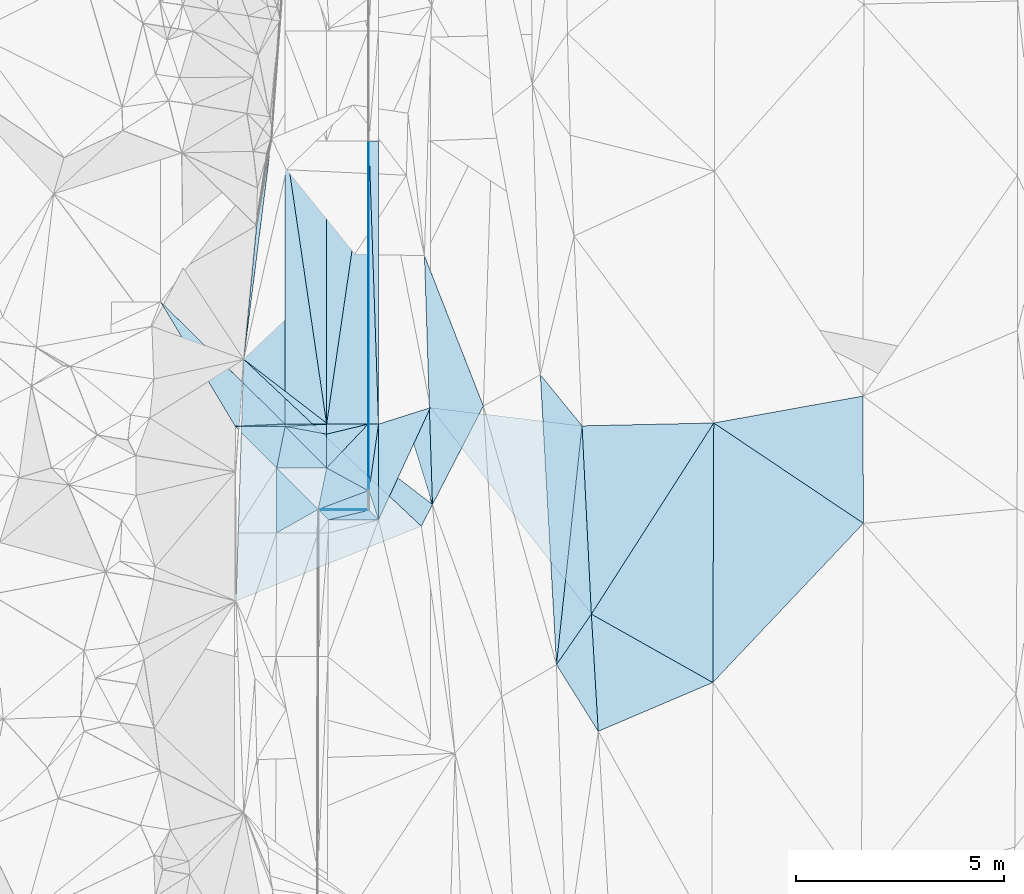
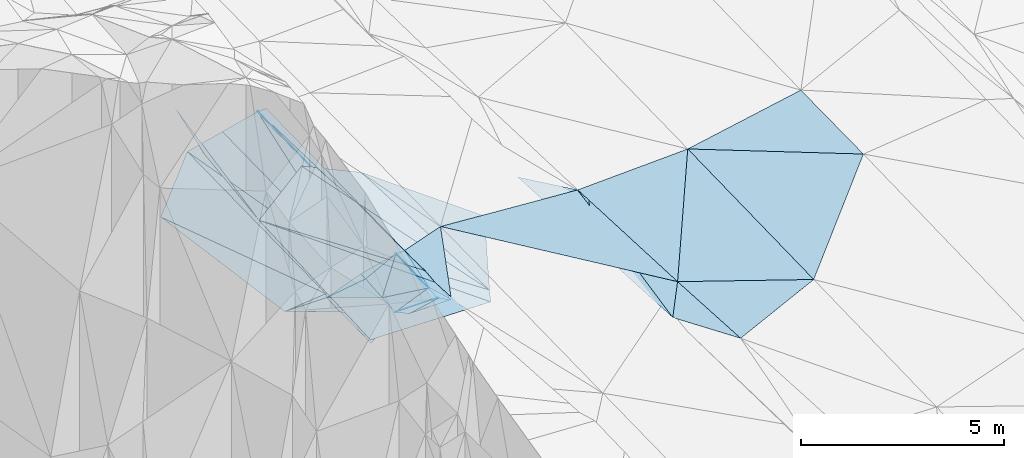
# One storey, part 129 of 275: 46 plates.
"""IFC2X3 building model written with IfcOpenShell, lengths in millimetres."""

import ifcopenshell
import ifcopenshell.guid

model = None  # the IFC model being written
_history = None  # IfcOwnerHistory: only IFC2X3 demands one
_inside = {}  # id of a spatial element -> (the spatial element, [elements in it])
_under = {}  # id of a project, library or spatial element -> (it, [spatial elements below it])
_declared = {}  # id of a project -> (the project, [libraries it declares])
_typed = {}  # id of a type object -> (the type object, [elements of that type])
_made_of = {}  # id of a material, layer set ... -> (it, [elements and type objects made of it])


def new_model(schema):
    """Start an empty IFC model of exactly this schema.

    Asked for "IFC4X3", IfcOpenShell would pick the latest addendum, in which some entities
    have other attributes; the version numbers below select the first issue.
    IFC2X3 requires an IfcOwnerHistory on every rooted entity: one is made here for all.
    """
    global model, _history
    if schema == "IFC4X3":
        model = ifcopenshell.file(schema_version=(4, 3, 0, 0))
    else:
        model = ifcopenshell.file(schema=schema)
    _inside.clear()
    _under.clear()
    _declared.clear()
    _typed.clear()
    _made_of.clear()
    _history = None
    if model.schema == "IFC2X3":
        org = make("IfcOrganization", Name="unknown")
        user = make(
            "IfcPersonAndOrganization",
            ThePerson=make("IfcPerson", FamilyName="unknown"),
            TheOrganization=org,
        )
        app = make(
            "IfcApplication",
            ApplicationDeveloper=org,
            Version="unknown",
            ApplicationFullName="unknown",
            ApplicationIdentifier="unknown",
        )
        _history = make(
            "IfcOwnerHistory",
            OwningUser=user,
            OwningApplication=app,
            ChangeAction="ADDED",
            CreationDate=0,
        )
    return model


def make(cls, **values):
    """One entity of the class cls with the attributes given. An attribute that is None is left unset."""
    return model.create_entity(
        cls, **{name: value for name, value in values.items() if value is not None}
    )


def rooted(cls, **values):
    """An entity with a GlobalId (a new one), such as an element, a storey or a relation."""
    return make(cls, GlobalId=ifcopenshell.guid.new(), OwnerHistory=_history, **values)


def si_unit(unit_type, name, prefix=None):
    """IfcSIUnit, for example si_unit("LENGTHUNIT", "METRE", prefix="MILLI")."""
    return make("IfcSIUnit", UnitType=unit_type, Prefix=prefix, Name=name)


def assignment(units):
    """IfcUnitAssignment: the units of a project."""
    return None if units is None else make("IfcUnitAssignment", Units=units)


def point(xyz):
    """IfcCartesianPoint."""
    return None if xyz is None else make("IfcCartesianPoint", Coordinates=xyz)


def direction(xyz):
    """IfcDirection."""
    return None if xyz is None else make("IfcDirection", DirectionRatios=xyz)


def frame(location, z_axis=None, x_axis=None):
    """IfcAxis2Placement3D, a coordinate frame: its origin and axes. An axis left out is left unset."""
    return make(
        "IfcAxis2Placement3D",
        Location=point(location),
        Axis=direction(z_axis),
        RefDirection=direction(x_axis),
    )


def origin_with_axes():
    """The frame at (0, 0, 0) with the z axis (0, 0, 1) and the x axis (1, 0, 0) written out."""
    return frame((0.0, 0.0, 0.0), z_axis=(0.0, 0.0, 1.0), x_axis=(1.0, 0.0, 0.0))


def place(relative_to, where):
    """IfcLocalPlacement: puts the frame where relative to a parent placement (None: the world)."""
    return make(
        "IfcLocalPlacement", PlacementRelTo=relative_to, RelativePlacement=where
    )


def context(
    kind, dimensions, precision=None, world=None, true_north=None, identifier=None
):
    """IfcGeometricRepresentationContext, for example the 3D "Model" context."""
    return make(
        "IfcGeometricRepresentationContext",
        ContextIdentifier=identifier,
        ContextType=kind,
        CoordinateSpaceDimension=dimensions,
        Precision=precision,
        WorldCoordinateSystem=world,
        TrueNorth=true_north,
    )


def subcontext(parent, identifier, kind, view, scale=None):
    """IfcGeometricRepresentationSubContext, for example "Body" below "Model"."""
    return make(
        "IfcGeometricRepresentationSubContext",
        ContextIdentifier=identifier,
        ContextType=kind,
        ParentContext=parent,
        TargetScale=scale,
        TargetView=view,
    )


def project(units=None, contexts=None):
    """IfcProject with its units and contexts."""
    return rooted(
        "IfcProject",
        Name="project",
        RepresentationContexts=contexts,
        UnitsInContext=assignment(units),
    )


def spatial(cls, under=None, at=None, **own):
    """A site, building, storey or space (cls), placed at a placement, below another one or the project."""
    s = rooted(cls, ObjectPlacement=at, **own)
    if under is not None:
        _under.setdefault(under.id(), (under, []))[1].append(s)
    return s


def polyline(points):
    """IfcPolyline through the points."""
    return make("IfcPolyline", Points=[point(p) for p in points])


def outline(outer, holes=None, kind="AREA"):
    """IfcArbitraryClosedProfileDef: a profile drawn as a closed curve; with holes, ...WithVoids."""
    if holes is None:
        return make("IfcArbitraryClosedProfileDef", ProfileType=kind, OuterCurve=outer)
    return make(
        "IfcArbitraryProfileDefWithVoids",
        ProfileType=kind,
        OuterCurve=outer,
        InnerCurves=holes,
    )


def extrude(swept, where, along, depth):
    """IfcExtrudedAreaSolid: the profile swept, set in the frame where, extruded along a direction by depth."""
    return make(
        "IfcExtrudedAreaSolid",
        SweptArea=swept,
        Position=where,
        ExtrudedDirection=direction(along),
        Depth=depth,
    )


def shape(context_of_items, identifier, shape_type, items):
    """IfcShapeRepresentation: the items that make up one representation, for example the "Body"."""
    return make(
        "IfcShapeRepresentation",
        ContextOfItems=context_of_items,
        RepresentationIdentifier=identifier,
        RepresentationType=shape_type,
        Items=items,
    )


def material(Name=None, Category=None):
    """IfcMaterial."""
    return make("IfcMaterial", Name=Name, Category=Category)


def made_of(thing, what):
    """Note that an element or type object is made of a material, layer set ...; save() writes the relation."""
    if what is not None:
        _made_of.setdefault(what.id(), (what, []))[1].append(thing)
    return thing


def type_object(cls, material=None, **own):
    """A type object (cls), such as IfcWallType, which elements share."""
    return made_of(rooted(cls, **own), material)


def element(
    cls,
    number,
    at=None,
    inside=None,
    cuts=None,
    type_object=None,
    material=None,
    context=None,
    identifier="Body",
    shape_type=None,
    held_by="IfcProductDefinitionShape",
    body=None,
    shapes=None,
    **own,
):
    """One element of the class cls, such as IfcWall. Its Tag is "e" and its number.

    at: its placement. inside: the storey or other place that contains it. cuts: it is an
    opening in that element (IfcRelVoidsElement). A single representation is given by context,
    identifier, shape_type and body (its items); several are given by shapes. held_by: the class
    of the entity that holds the representations. save() writes the other relations.
    """
    e = rooted(cls, Tag="e%d" % number, ObjectPlacement=at, **own)
    if body is not None:
        shapes = [shape(context, identifier, shape_type, body)]
    if shapes is not None:
        e.Representation = make(held_by, Representations=shapes)
    if inside is not None:
        _inside.setdefault(inside.id(), (inside, []))[1].append(e)
    if cuts is not None:
        rooted(
            "IfcRelVoidsElement", RelatingBuildingElement=cuts, RelatedOpeningElement=e
        )
    if type_object is not None:
        _typed.setdefault(type_object.id(), (type_object, []))[1].append(e)
    return made_of(e, material)


def aggregate(whole, parts):
    """IfcRelAggregates: a whole, such as a stair, and the parts it consists of."""
    return rooted("IfcRelAggregates", RelatingObject=whole, RelatedObjects=parts)


def save(model, path):
    """Write the relations noted so far, then the file.

    IfcRelAggregates (storeys below a building ...), IfcRelContainedInSpatialStructure (elements
    in a storey), IfcRelDefinesByType, IfcRelAssociatesMaterial and IfcRelDeclares: one each for
    every whole, place, type object, material and project.
    """
    for whole, parts in _under.values():
        aggregate(whole, parts)
    for where, things in _inside.values():
        rooted(
            "IfcRelContainedInSpatialStructure",
            RelatedElements=things,
            RelatingStructure=where,
        )
    for kind, things in _typed.values():
        rooted("IfcRelDefinesByType", RelatedObjects=things, RelatingType=kind)
    for what, things in _made_of.values():
        rooted("IfcRelAssociatesMaterial", RelatedObjects=things, RelatingMaterial=what)
    for by, libraries in _declared.values():
        rooted("IfcRelDeclares", RelatingContext=by, RelatedDefinitions=libraries)
    model.write(path)


model = new_model("IFC2X3")

# Units and contexts
model_context = context("Model", 3, precision=1e-05, world=origin_with_axes())
body_context = subcontext(model_context, "Body", "Model", "MODEL_VIEW")
ifc_project = project(units=[si_unit("LENGTHUNIT", "METRE", prefix="MILLI"), si_unit("AREAUNIT", "SQUARE_METRE"), si_unit("VOLUMEUNIT", "CUBIC_METRE"), si_unit("MASSUNIT", "GRAM", prefix="KILO"), si_unit("TIMEUNIT", "SECOND"), si_unit("PLANEANGLEUNIT", "RADIAN"), si_unit("SOLIDANGLEUNIT", "STERADIAN"), si_unit("THERMODYNAMICTEMPERATUREUNIT", "DEGREE_CELSIUS"), si_unit("LUMINOUSINTENSITYUNIT", "LUMEN")], contexts=[model_context])

# Site, building, storey
site_placement = place(None, origin_with_axes())
site = spatial("IfcSite", under=ifc_project, at=site_placement, CompositionType="ELEMENT")
building_placement = place(site_placement, origin_with_axes())
building = spatial("IfcBuilding", under=site, at=building_placement, Name="Undefined", CompositionType="ELEMENT")
storey_placement = place(building_placement, origin_with_axes())
storey = spatial("IfcBuildingStorey", under=building, at=storey_placement, Name="Undefined", CompositionType="ELEMENT", Elevation=0.0)

# Plates
ifc_material = material()
plate_type_1 = type_object("IfcPlateType", PredefinedType="NOTDEFINED")
plate_1_placement = place(storey_placement, frame((-97653.2887864326, 105542.547100764, 42493.7394026533), z_axis=(0.312892359735488, 0.0336666386095785, -0.949191723870309), x_axis=(0.947866294842102, 0.0524820300685119, 0.314316915902079)))
element("IfcPlate", 1, at=plate_1_placement, inside=storey, type_object=plate_type_1, material=ifc_material, Name="00_PR", context=body_context, shape_type="SweptSolid", body=[
    extrude(outline(polyline([(0.0, 0.0), (1054.98303222656, 7.8580342233181e-10), (1039.69421386719, 241.215286254883), (0.0, 0.0)])), frame((-8.85201319254618e-08, 2.18876761149539e-07, -0.5000001331573), z_axis=(0.0, 0.0, 1.0), x_axis=(1.0, 0.0, 0.0)), (0.0, 0.0, 1.0), 1.0),
])
plate_type_2 = type_object("IfcPlateType", PredefinedType="NOTDEFINED")
plate_2_placement = place(storey_placement, frame((-95655.6246239259, 112422.738065475, 43216.1967279193), z_axis=(0.0499223744900721, 0.0206295436102709, -0.998540023462107), x_axis=(0.998752208044659, 0.000305680057574922, 0.0499392980088953)))
element("IfcPlate", 2, at=plate_2_placement, inside=storey, type_object=plate_type_2, material=ifc_material, Name="00_PR", context=body_context, shape_type="SweptSolid", body=[
    extrude(outline(polyline([(0.0, 0.0), (20.0243110656738, 1.45519152283669e-11), (-6.93724489212036, 6825.95947265625), (0.0, 0.0)])), frame((-8.85201319254618e-08, 2.18876761149539e-07, -0.5000001331573), z_axis=(0.0, 0.0, 1.0), x_axis=(1.0, 0.0, 0.0)), (0.0, 0.0, 1.0), 1.0),
])
plate_3_placement = place(storey_placement, frame((-95635.6252984131, 112422.744185168, 43217.1967278183), z_axis=(0.0499223744900721, 0.0206295436102709, -0.998540023462107), x_axis=(0.000320483071139451, -0.99978693596693, -0.0206392819753496)))
element("IfcPlate", 3, at=plate_3_placement, inside=storey, type_object=plate_type_2, material=ifc_material, Name="00_PR", context=body_context, shape_type="SweptSolid", body=[
    extrude(outline(polyline([(0.0, 0.0), (6825.96337890625, 3.34839569404721e-08), (6825.9833984375, 20.024299621582), (0.0, 0.0)])), frame((-8.85201319254618e-08, 2.18876761149539e-07, -0.5000001331573), z_axis=(0.0, 0.0, 1.0), x_axis=(1.0, 0.0, 0.0)), (0.0, 0.0, 1.0), 1.0),
])
plate_4_placement = place(storey_placement, frame((-95653.4374348788, 105598.236543643, 43075.3139315699), z_axis=(0.0498975874379128, 0.0352089020594793, -0.998133540155646), x_axis=(0.998752208044659, 0.000305680057574922, 0.0499392980088953)))
element("IfcPlate", 4, at=plate_4_placement, inside=storey, type_object=plate_type_2, material=ifc_material, Name="00_PR", context=body_context, shape_type="SweptSolid", body=[
    extrude(outline(polyline([(0.0, 0.0), (20.0243110656738, 1.45519152283669e-11), (-2.80114841461182, 1604.79565429688), (0.0, 0.0)])), frame((-8.85201319254618e-08, 2.18876761149539e-07, -0.5000001331573), z_axis=(0.0, 0.0, 1.0), x_axis=(1.0, 0.0, 0.0)), (0.0, 0.0, 1.0), 1.0),
])
plate_5_placement = place(storey_placement, frame((-95633.4381117361, 105598.242665022, 43076.3139315634), z_axis=(0.049894601856358, 0.0352089441059493, -0.99813368791988), x_axis=(0.000320679087443506, -0.999378938278334, -0.0352368399632018)))
element("IfcPlate", 5, at=plate_5_placement, inside=storey, type_object=plate_type_2, material=ifc_material, Name="00_PR", context=body_context, shape_type="SweptSolid", body=[
    extrude(outline(polyline([(0.0, 0.0), (1604.79772949219, 7.02857505530119e-09), (1604.8330078125, 20.0251922607422), (0.0, 0.0)])), frame((-8.85201319254618e-08, 2.18876761149539e-07, -0.5000001331573), z_axis=(0.0, 0.0, 1.0), x_axis=(1.0, 0.0, 0.0)), (0.0, 0.0, 1.0), 1.0),
])
plate_6_placement = place(storey_placement, frame((-95632.7954361598, 103522.392015706, 42994.7145218657), z_axis=(0.00441215188148387, -0.0455324207746714, -0.998953117805922), x_axis=(-0.999990232290027, 5.52519184112805e-05, -0.00441953298023441)))
element("IfcPlate", 6, at=plate_6_placement, inside=storey, type_object=plate_type_2, material=ifc_material, Name="00_PR", context=body_context, shape_type="SweptSolid", body=[
    extrude(outline(polyline([(0.0, 0.0), (1207.6669921875, -1.92085281014442e-09), (20.0108661651611, 20.020471572876), (0.0, 0.0)])), frame((-8.85201319254618e-08, 2.18876761149539e-07, -0.5000001331573), z_axis=(0.0, 0.0, 1.0), x_axis=(1.0, 0.0, 0.0)), (0.0, 0.0, 1.0), 1.0),
])
plate_7_placement = place(storey_placement, frame((-95652.8009657944, 103542.392823774, 42993.7145216319), z_axis=(0.00441242987111564, -0.0455490928932025, -0.99895235652119), x_axis=(-0.999852510334156, -0.0167817230790886, -0.00365121198830028)))
element("IfcPlate", 7, at=plate_7_placement, inside=storey, type_object=plate_type_2, material=ifc_material, Name="00_PR", context=body_context, shape_type="SweptSolid", body=[
    extrude(outline(polyline([(0.0, 0.0), (1187.82482910156, -2.95403879135847e-09), (1207.42211914063, 20.3533382415771), (0.0, 0.0)])), frame((-8.85201319254618e-08, 2.18876761149539e-07, -0.5000001331573), z_axis=(0.0, 0.0, 1.0), x_axis=(1.0, 0.0, 0.0)), (0.0, 0.0, 1.0), 1.0),
])
plate_type_3 = type_object("IfcPlateType", PredefinedType="NOTDEFINED")
plate_8_placement = place(storey_placement, frame((-96653.3411720604, 105597.90797045, 42825.3280256418), z_axis=(0.242480539180767, 0.0201010242110284, -0.96994800734074), x_axis=(-0.970142403271045, -0.000311047105442569, -0.242535813077531)))
element("IfcPlate", 8, at=plate_8_placement, inside=storey, type_object=plate_type_3, material=ifc_material, Name="00_PR", context=body_context, shape_type="SweptSolid", body=[
    extrude(outline(polyline([(0.0, 0.0), (1030.77648925781, -5.90807758271694e-09), (996.604248046875, 6825.87841796875), (0.0, 0.0)])), frame((-8.85201319254618e-08, 2.18876761149539e-07, -0.5000001331573), z_axis=(0.0, 0.0, 1.0), x_axis=(1.0, 0.0, 0.0)), (0.0, 0.0, 1.0), 1.0),
])
plate_9_placement = place(storey_placement, frame((-97655.5288255688, 112422.096666307, 42716.2110240052), z_axis=(0.242480539180767, 0.0201010242110284, -0.96994800734074), x_axis=(0.970142455388523, 0.000311440077304942, 0.242535604103411)))
element("IfcPlate", 9, at=plate_9_placement, inside=storey, type_object=plate_type_3, material=ifc_material, Name="00_PR", context=body_context, shape_type="SweptSolid", body=[
    extrude(outline(polyline([(0.0, 0.0), (1030.77648925781, -5.90807758271694e-09), (996.604187011719, 6825.87841796875), (0.0, 0.0)])), frame((-8.85201319254618e-08, 2.18876761149539e-07, -0.5000001331573), z_axis=(0.0, 0.0, 1.0), x_axis=(1.0, 0.0, 0.0)), (0.0, 0.0, 1.0), 1.0),
])
plate_type_4 = type_object("IfcPlateType", PredefinedType="NOTDEFINED")
plate_10_placement = place(storey_placement, frame((-95635.6252984131, 112422.744185168, 43217.1967278183), z_axis=(0.0499202695724449, 0.0206295454221238, -0.998540128658579), x_axis=(0.998752289393171, 0.000323471066674541, 0.0499375589949035)))
element("IfcPlate", 10, at=plate_10_placement, inside=storey, type_object=plate_type_4, material=ifc_material, Name="00_PR", context=body_context, shape_type="SweptSolid", body=[
    extrude(outline(polyline([(0.0, 0.0), (230.287582397461, -1.16415321826935e-10), (223.229583740234, 6825.96044921875), (0.0, 0.0)])), frame((-8.85201319254618e-08, 2.18876761149539e-07, -0.5000001331573), z_axis=(0.0, 0.0, 1.0), x_axis=(1.0, 0.0, 0.0)), (0.0, 0.0, 1.0), 1.0),
])
plate_11_placement = place(storey_placement, frame((-95403.4374353399, 105598.308952876, 43087.8137283719), z_axis=(0.0499202695724449, 0.0206295454221238, -0.998540128658579), x_axis=(-0.998752295023271, -0.000319498066804367, -0.0499374719698073)))
element("IfcPlate", 11, at=plate_11_placement, inside=storey, type_object=plate_type_4, material=ifc_material, Name="00_PR", context=body_context, shape_type="SweptSolid", body=[
    extrude(outline(polyline([(0.0, 0.0), (230.287994384766, 9.60426405072212e-10), (223.256713867188, 6825.95947265625), (0.0, 0.0)])), frame((-8.85201319254618e-08, 2.18876761149539e-07, -0.5000001331573), z_axis=(0.0, 0.0, 1.0), x_axis=(1.0, 0.0, 0.0)), (0.0, 0.0, 1.0), 1.0),
])
plate_12_placement = place(storey_placement, frame((-95632.9239308959, 103994.441690394, 43019.765911747), z_axis=(0.0490039818531292, 0.0353381512755968, -0.998173243894546), x_axis=(0.141515003891181, 0.989046333769192, 0.0419625229389179)))
element("IfcPlate", 12, at=plate_12_placement, inside=storey, type_object=plate_type_4, material=ifc_material, Name="00_PR", context=body_context, shape_type="SweptSolid", body=[
    extrude(outline(polyline([(0.0, 0.0), (1621.63745117188, 1.05210347101092e-08), (-662.321350097656, 327.6484375), (0.0, 0.0)])), frame((-8.85201319254618e-08, 2.18876761149539e-07, -0.5000001331573), z_axis=(0.0, 0.0, 1.0), x_axis=(1.0, 0.0, 0.0)), (0.0, 0.0, 1.0), 1.0),
])
plate_13_placement = place(storey_placement, frame((-95632.7954361598, 103522.392015706, 42994.7145218657), z_axis=(0.00440892437051324, -0.0455346349813954, -0.998953031129595), x_axis=(0.706758614821674, -0.706572215713133, 0.0353265389980809)))
element("IfcPlate", 13, at=plate_13_placement, inside=storey, type_object=plate_type_4, material=ifc_material, Name="00_PR", context=body_context, shape_type="SweptSolid", body=[
    extrude(outline(polyline([(0.0, 0.0), (325.534301757813, 3.62888386007398e-10), (-528.830078125, 854.747009277344), (0.0, 0.0)])), frame((-8.85201319254618e-08, 2.18876761149539e-07, -0.5000001331573), z_axis=(0.0, 0.0, 1.0), x_axis=(1.0, 0.0, 0.0)), (0.0, 0.0, 1.0), 1.0),
])
plate_14_placement = place(storey_placement, frame((-96611.23374733, 103292.448182768, 43000.8775216555), z_axis=(0.00441214773488253, -0.0455483362832968, -0.998952392266113), x_axis=(-0.705440935818661, 0.70788449171914, -0.0353925480126398)))
element("IfcPlate", 14, at=plate_14_placement, inside=storey, type_object=plate_type_4, material=ifc_material, Name="00_PR", context=body_context, shape_type="SweptSolid", body=[
    extrude(outline(polyline([(0.0, 0.0), (324.927154541016, -3.71983333025128e-10), (-527.238647460938, 855.729553222656), (0.0, 0.0)])), frame((-8.85201319254618e-08, 2.18876761149539e-07, -0.5000001331573), z_axis=(0.0, 0.0, 1.0), x_axis=(1.0, 0.0, 0.0)), (0.0, 0.0, 1.0), 1.0),
])
plate_type_5 = type_object("IfcPlateType", PredefinedType="NOTDEFINED")
plate_15_placement = place(storey_placement, frame((-100654.386689466, 108542.953911166, 44147.5779243055), z_axis=(0.0396122744760704, 0.501672436813122, -0.864150238010044), x_axis=(0.668508670926033, -0.656074341843081, -0.350232229915918)))
element("IfcPlate", 15, at=plate_15_placement, inside=storey, type_object=plate_type_5, material=ifc_material, Name="00_PR", context=body_context, shape_type="SweptSolid", body=[
    extrude(outline(polyline([(0.0, 0.0), (4489.0126953125, 3.69327608495951e-08), (3753.52294921875, 953.418518066406), (0.0, 0.0)])), frame((-8.85201319254618e-08, 2.18876761149539e-07, -0.5000001331573), z_axis=(0.0, 0.0, 1.0), x_axis=(1.0, 0.0, 0.0)), (0.0, 0.0, 1.0), 1.0),
])
plate_type_6 = type_object("IfcPlateType", PredefinedType="NOTDEFINED")
plate_16_placement = place(storey_placement, frame((-97655.8749804858, 112422.095759161, 42716.2495411384), z_axis=(-0.449850908170147, 0.018288880229569, -0.892916388738857), x_axis=(0.000320483071139451, -0.99978693596693, -0.0206392819753496)))
element("IfcPlate", 16, at=plate_16_placement, inside=storey, type_object=plate_type_6, material=ifc_material, Name="00_PR", context=body_context, shape_type="SweptSolid", body=[
    extrude(outline(polyline([(0.0, 0.0), (6825.9638671875, 9.77888703346252e-09), (3848.0546875, 3359.06127929688), (0.0, 0.0)])), frame((-8.85201319254618e-08, 2.18876761149539e-07, -0.5000001331573), z_axis=(0.0, 0.0, 1.0), x_axis=(1.0, 0.0, 0.0)), (0.0, 0.0, 1.0), 1.0),
])
plate_type_7 = type_object("IfcPlateType", PredefinedType="NOTDEFINED")
plate_17_placement = place(storey_placement, frame((-97653.443979192, 105542.944770362, 42493.9343780925), z_axis=(0.00250687886112322, 0.829000339173588, -0.559242481584198), x_axis=(-0.99999010568678, 2.3083920952297e-05, -0.00444837000210097)))
element("IfcPlate", 17, at=plate_17_placement, inside=storey, type_object=plate_type_7, material=ifc_material, Name="00_PR", context=body_context, shape_type="SweptSolid", body=[
    extrude(outline(polyline([(0.0, 0.0), (1199.76538085938, 8.23638401925564e-09), (-0.344492018222809, 98.4297180175781), (0.0, 0.0)])), frame((-8.85201319254618e-08, 2.18876761149539e-07, -0.5000001331573), z_axis=(0.0, 0.0, 1.0), x_axis=(1.0, 0.0, 0.0)), (0.0, 0.0, 1.0), 1.0),
])
plate_type_8 = type_object("IfcPlateType", PredefinedType="NOTDEFINED")
plate_18_placement = place(storey_placement, frame((-97856.871913565, 104542.381525309, 42738.3914295413), z_axis=(0.00431452632143643, -0.238472600232204, -0.971139641761736), x_axis=(-0.694969408010111, 0.697572935905946, -0.174383259006232)))
element("IfcPlate", 18, at=plate_18_placement, inside=storey, type_object=plate_type_8, material=ifc_material, Name="00_PR", context=body_context, shape_type="SweptSolid", body=[
    extrude(outline(polyline([(0.0, 0.0), (1433.62390136719, -5.64796209800988e-10), (598.8818359375, 861.767272949219), (0.0, 0.0)])), frame((-8.85201319254618e-08, 2.18876761149539e-07, -0.5000001331573), z_axis=(0.0, 0.0, 1.0), x_axis=(1.0, 0.0, 0.0)), (0.0, 0.0, 1.0), 1.0),
])
plate_type_9 = type_object("IfcPlateType", PredefinedType="NOTDEFINED")
plate_19_placement = place(storey_placement, frame((-96653.3411720604, 105597.90797045, 42825.3280256418), z_axis=(0.242480539180767, 0.0201010242110284, -0.96994800734074), x_axis=(-0.000320483060127504, 0.999786935966934, 0.0206392819753454)))
element("IfcPlate", 19, at=plate_19_placement, inside=storey, type_object=plate_type_9, material=ifc_material, Name="00_PR", context=body_context, shape_type="SweptSolid", body=[
    extrude(outline(polyline([(0.0, 0.0), (6825.9638671875, 9.77888703346252e-09), (6831.12353515625, 1030.76391601563), (0.0, 0.0)])), frame((-8.85201319254618e-08, 2.18876761149539e-07, -0.5000001331573), z_axis=(0.0, 0.0, 1.0), x_axis=(1.0, 0.0, 0.0)), (0.0, 0.0, 1.0), 1.0),
])
plate_20_placement = place(storey_placement, frame((-95655.5283421946, 112422.7378013, 43216.2110242434), z_axis=(0.242480539180767, 0.0201010242110284, -0.96994800734074), x_axis=(0.000320483071139451, -0.99978693596693, -0.0206392819753496)))
element("IfcPlate", 20, at=plate_20_placement, inside=storey, type_object=plate_type_9, material=ifc_material, Name="00_PR", context=body_context, shape_type="SweptSolid", body=[
    extrude(outline(polyline([(0.0, 0.0), (6825.96337890625, 3.34839569404721e-08), (6831.12353515625, 1030.76354980469), (0.0, 0.0)])), frame((-8.85201319254618e-08, 2.18876761149539e-07, -0.5000001331573), z_axis=(0.0, 0.0, 1.0), x_axis=(1.0, 0.0, 0.0)), (0.0, 0.0, 1.0), 1.0),
])
plate_type_10 = type_object("IfcPlateType", PredefinedType="NOTDEFINED")
plate_21_placement = place(storey_placement, frame((-96653.2641231825, 105356.366778962, 42816.786212235), z_axis=(0.242381979988419, 0.0343648532394237, -0.969572087386351), x_axis=(-0.000318995060751149, 0.999375245590733, 0.0353414309644342)))
element("IfcPlate", 21, at=plate_21_placement, inside=storey, type_object=plate_type_10, material=ifc_material, Name="00_PR", context=body_context, shape_type="SweptSolid", body=[
    extrude(outline(polyline([(0.0, 0.0), (241.699325561523, 2.91038304567337e-11), (250.536514282227, 1030.73864746094), (0.0, 0.0)])), frame((-8.85201319254618e-08, 2.18876761149539e-07, -0.5000001331573), z_axis=(0.0, 0.0, 1.0), x_axis=(1.0, 0.0, 0.0)), (0.0, 0.0, 1.0), 1.0),
])
plate_type_11 = type_object("IfcPlateType", PredefinedType="NOTDEFINED")
plate_22_placement = place(storey_placement, frame((-96860.3243602455, 103542.352553635, 42988.3979540504), z_axis=(0.121257849280443, -0.259543272970803, -0.95808863026522), x_axis=(0.197364533996599, 0.952243222304352, -0.232980871094024)))
element("IfcPlate", 22, at=plate_22_placement, inside=storey, type_object=plate_type_11, material=ifc_material, Name="00_PR", context=body_context, shape_type="SweptSolid", body=[
    extrude(outline(polyline([(0.0, 0.0), (1050.14196777344, 2.38651409745216e-09), (661.577514648438, 1106.97180175781), (0.0, 0.0)])), frame((-8.85201319254618e-08, 2.18876761149539e-07, -0.5000001331573), z_axis=(0.0, 0.0, 1.0), x_axis=(1.0, 0.0, 0.0)), (0.0, 0.0, 1.0), 1.0),
])
plate_type_12 = type_object("IfcPlateType", PredefinedType="NOTDEFINED")
plate_23_placement = place(storey_placement, frame((-95652.8075513964, 103994.434446308, 43018.7856245645), z_axis=(0.282231050332636, 0.0338946188764721, -0.958747510577918), x_axis=(-0.852528289984673, 0.467150762908405, -0.234447604999292)))
element("IfcPlate", 23, at=plate_23_placement, inside=storey, type_object=plate_type_12, material=ifc_material, Name="00_PR", context=body_context, shape_type="SweptSolid", body=[
    extrude(outline(polyline([(0.0, 0.0), (1173.1875, 2.56841303780675e-09), (736.3974609375, 1425.86669921875), (0.0, 0.0)])), frame((-8.85201319254618e-08, 2.18876761149539e-07, -0.5000001331573), z_axis=(0.0, 0.0, 1.0), x_axis=(1.0, 0.0, 0.0)), (0.0, 0.0, 1.0), 1.0),
])
plate_type_13 = type_object("IfcPlateType", PredefinedType="NOTDEFINED")
plate_24_placement = place(storey_placement, frame((-97862.1815405883, 102977.62756625, 42736.9830312004), z_axis=(0.243366998943034, 2.8987444274913e-05, -0.969934277662765), x_axis=(0.00346936493834427, 0.999993576384478, 0.0009003869761755)))
element("IfcPlate", 24, at=plate_24_placement, inside=storey, type_object=plate_type_13, material=ifc_material, Name="00_PR", context=body_context, shape_type="SweptSolid", body=[
    extrude(outline(polyline([(0.0, 0.0), (1564.88330078125, -1.12340785562992e-08), (568.553527832031, 1030.94836425781), (0.0, 0.0)])), frame((-8.85201319254618e-08, 2.18876761149539e-07, -0.5000001331573), z_axis=(0.0, 0.0, 1.0), x_axis=(1.0, 0.0, 0.0)), (0.0, 0.0, 1.0), 1.0),
])
plate_type_14 = type_object("IfcPlateType", PredefinedType="NOTDEFINED")
plate_25_placement = place(storey_placement, frame((-96653.3933227678, 105598.308446895, 42825.5360693074), z_axis=(0.138200955003459, 0.82106128260087, -0.553858164379605), x_axis=(-0.947866294829478, -0.0524820300832829, -0.31431691593768)))
element("IfcPlate", 25, at=plate_25_placement, inside=storey, type_object=plate_type_14, material=ifc_material, Name="00_PR", context=body_context, shape_type="SweptSolid", body=[
    extrude(outline(polyline([(0.0, 0.0), (1054.98303222656, 7.8580342233181e-10), (1026.46240234375, 94.2077713012695), (0.0, 0.0)])), frame((-8.85201319254618e-08, 2.18876761149539e-07, -0.5000001331573), z_axis=(0.0, 0.0, 1.0), x_axis=(1.0, 0.0, 0.0)), (0.0, 0.0, 1.0), 1.0),
])
plate_type_15 = type_object("IfcPlateType", PredefinedType="NOTDEFINED")
plate_26_placement = place(storey_placement, frame((-97653.2849661297, 105542.572660633, 42493.7422834695), z_axis=(0.320548432622101, 0.0847890626417407, -0.943429656731147), x_axis=(0.936991761166118, -0.174439304948929, 0.302683611045844)))
element("IfcPlate", 26, at=plate_26_placement, inside=storey, type_object=plate_type_15, material=ifc_material, Name="00_PR", context=body_context, shape_type="SweptSolid", body=[
    extrude(outline(polyline([(0.0, 0.0), (1067.30920410156, 3.18686943501234e-09), (1187.41271972656, 808.274536132813), (0.0, 0.0)])), frame((-8.85201319254618e-08, 2.18876761149539e-07, -0.5000001331573), z_axis=(0.0, 0.0, 1.0), x_axis=(1.0, 0.0, 0.0)), (0.0, 0.0, 1.0), 1.0),
])
plate_type_16 = type_object("IfcPlateType", PredefinedType="NOTDEFINED")
plate_27_placement = place(storey_placement, frame((-96653.0094188309, 104542.516477107, 42743.7293055316), z_axis=(0.229580214099796, 0.0870897861553216, -0.969385524155025), x_axis=(-0.000319541079109733, 0.995995326572031, 0.0894047389133926)))
element("IfcPlate", 27, at=plate_27_placement, inside=storey, type_object=plate_type_16, material=ifc_material, Name="00_PR", context=body_context, shape_type="SweptSolid", body=[
    extrude(outline(polyline([(0.0, 0.0), (817.149047851563, 4.32191882282496e-09), (1080.84521484375, 1027.45068359375), (0.0, 0.0)])), frame((-8.85201319254618e-08, 2.18876761149539e-07, -0.5000001331573), z_axis=(0.0, 0.0, 1.0), x_axis=(1.0, 0.0, 0.0)), (0.0, 0.0, 1.0), 1.0),
])
plate_type_17 = type_object("IfcPlateType", PredefinedType="NOTDEFINED")
plate_28_placement = place(storey_placement, frame((-95652.8009687595, 103542.44326702, 42993.7147695128), z_axis=(0.0044158182892725, 0.0553382885159322, -0.99845789814742), x_axis=(-0.999990232290027, 5.52519184112805e-05, -0.00441953298023441)))
element("IfcPlate", 28, at=plate_28_placement, inside=storey, type_object=plate_type_17, material=ifc_material, Name="00_PR", context=body_context, shape_type="SweptSolid", body=[
    extrude(outline(polyline([(0.0, 0.0), (1207.59362792969, 6.12635631114244e-09), (0.0597549267113209, 452.695587158203), (0.0, 0.0)])), frame((-8.85201319254618e-08, 2.18876761149539e-07, -0.5000001331573), z_axis=(0.0, 0.0, 1.0), x_axis=(1.0, 0.0, 0.0)), (0.0, 0.0, 1.0), 1.0),
])
plate_type_18 = type_object("IfcPlateType", PredefinedType="NOTDEFINED")
plate_29_placement = place(storey_placement, frame((-96653.1220530738, 104542.353698838, 42743.7284284005), z_axis=(0.0043001799457677, -0.238469862280149, -0.971140377719164), x_axis=(-0.99999017127131, 2.31149398480002e-05, -0.00443360197533974)))
element("IfcPlate", 29, at=plate_29_placement, inside=storey, type_object=plate_type_18, material=ifc_material, Name="00_PR", context=body_context, shape_type="SweptSolid", body=[
    extrude(outline(polyline([(0.0, 0.0), (1203.76171875, -8.1199686974287e-09), (1001.44268798828, 1029.74230957031), (0.0, 0.0)])), frame((-8.85201319254618e-08, 2.18876761149539e-07, -0.5000001331573), z_axis=(0.0, 0.0, 1.0), x_axis=(1.0, 0.0, 0.0)), (0.0, 0.0, 1.0), 1.0),
])
plate_type_19 = type_object("IfcPlateType", PredefinedType="NOTDEFINED")
plate_30_placement = place(storey_placement, frame((-95633.4381117361, 105598.242665022, 43076.3139315634), z_axis=(0.049894601856358, 0.0352089441059493, -0.99813368791988), x_axis=(0.998752295023223, 0.000319498061117144, 0.0499374719708001)))
element("IfcPlate", 30, at=plate_30_placement, inside=storey, type_object=plate_type_19, material=ifc_material, Name="00_PR", context=body_context, shape_type="SweptSolid", body=[
    extrude(outline(polyline([(0.0, 0.0), (230.287994384766, 9.60426405072212e-10), (-2.82229280471802, 1604.79528808594), (0.0, 0.0)])), frame((-8.85201319254618e-08, 2.18876761149539e-07, -0.5000001331573), z_axis=(0.0, 0.0, 1.0), x_axis=(1.0, 0.0, 0.0)), (0.0, 0.0, 1.0), 1.0),
])
plate_type_20 = type_object("IfcPlateType", PredefinedType="NOTDEFINED")
plate_31_placement = place(storey_placement, frame((-95403.4508147161, 105598.316319072, 43087.8134447964), z_axis=(0.0231529093297936, 0.0353628853189836, -0.999106305220562), x_axis=(0.952600541110196, 0.302452734087164, 0.0327803709521621)))
element("IfcPlate", 31, at=plate_31_placement, inside=storey, type_object=plate_type_20, material=ifc_material, Name="00_PR", context=body_context, shape_type="SweptSolid", body=[
    extrude(outline(polyline([(0.0, 0.0), (1312.06567382813, 6.79574441164732e-09), (-699.395874023438, 2198.78759765625), (0.0, 0.0)])), frame((-8.85201319254618e-08, 2.18876761149539e-07, -0.5000001331573), z_axis=(0.0, 0.0, 1.0), x_axis=(1.0, 0.0, 0.0)), (0.0, 0.0, 1.0), 1.0),
])
plate_type_21 = type_object("IfcPlateType", PredefinedType="NOTDEFINED")
plate_32_placement = place(storey_placement, frame((-90499.2766121977, 105557.014575973, 43219.5002869348), z_axis=(0.0267691317099895, 0.0209906945555188, -0.999421234680137), x_axis=(0.0492158350862802, -0.998594751792996, -0.0196551079428246)))
element("IfcPlate", 32, at=plate_32_placement, inside=storey, type_object=plate_type_21, material=ifc_material, Name="00_PR", context=body_context, shape_type="SweptSolid", body=[
    extrude(outline(polyline([(0.0, 0.0), (4543.39892578125, 1.68365659192204e-08), (-615.623107910156, 3629.70043945313), (0.0, 0.0)])), frame((-8.85201319254618e-08, 2.18876761149539e-07, -0.5000001331573), z_axis=(0.0, 0.0, 1.0), x_axis=(1.0, 0.0, 0.0)), (0.0, 0.0, 1.0), 1.0),
])
plate_type_22 = type_object("IfcPlateType", PredefinedType="NOTDEFINED")
plate_33_placement = place(storey_placement, frame((-91116.0250301839, 99802.2167746713, 43081.5003366439), z_axis=(0.0311999345467619, 0.0206194720257955, -0.999300456047957), x_axis=(-0.0555447056220934, 0.998277981709266, 0.018864170054065)))
element("IfcPlate", 33, at=plate_33_placement, inside=storey, type_object=plate_type_22, material=ifc_material, Name="00", context=body_context, shape_type="SweptSolid", body=[
    extrude(outline(polyline([(0.0, 0.0), (6997.392578125, -1.95141183212399e-08), (5713.23388671875, 935.991760253906), (0.0, 0.0)])), frame((-8.85201319254618e-08, 2.18876761149539e-07, -0.5000001331573), z_axis=(0.0, 0.0, 1.0), x_axis=(1.0, 0.0, 0.0)), (0.0, 0.0, 1.0), 1.0),
])
plate_type_23 = type_object("IfcPlateType", PredefinedType="NOTDEFINED")
plate_34_placement = place(storey_placement, frame((-98651.1609641569, 107158.703037534, 44186.5222809982), z_axis=(-0.290885152120187, 0.0509123549347261, -0.955402407570243), x_axis=(0.764510184454641, -0.58802634763891, -0.26410072386795)))
element("IfcPlate", 34, at=plate_34_placement, inside=storey, type_object=plate_type_23, material=ifc_material, Name="00", context=body_context, shape_type="SweptSolid", body=[
    extrude(outline(polyline([(0.0, 0.0), (5948.48828125, -1.81462382897735e-08), (6035.85888671875, 583.345825195313), (0.0, 0.0)])), frame((-8.85201319254618e-08, 2.18876761149539e-07, -0.5000001331573), z_axis=(0.0, 0.0, 1.0), x_axis=(1.0, 0.0, 0.0)), (0.0, 0.0, 1.0), 1.0),
])
plate_type_24 = type_object("IfcPlateType", PredefinedType="NOTDEFINED")
plate_35_placement = place(storey_placement, frame((-91116.0274029556, 99802.2170272721, 43081.500274072), z_axis=(0.0264660023313546, 0.0211298340695007, -0.999426375894089), x_axis=(0.106531038279152, 0.994023616752186, 0.02383667808375)))
element("IfcPlate", 35, at=plate_35_placement, inside=storey, type_object=plate_type_24, material=ifc_material, Name="00", context=body_context, shape_type="SweptSolid", body=[
    extrude(outline(polyline([(0.0, 0.0), (5789.3974609375, -3.7209247238934e-08), (1301.17358398438, 706.008666992188), (0.0, 0.0)])), frame((-8.85201319254618e-08, 2.18876761149539e-07, -0.5000001331573), z_axis=(0.0, 0.0, 1.0), x_axis=(1.0, 0.0, 0.0)), (0.0, 0.0, 1.0), 1.0),
])
plate_type_25 = type_object("IfcPlateType", PredefinedType="NOTDEFINED")
plate_36_placement = place(storey_placement, frame((-97978.5751798975, 112478.767794133, 44125.5389791349), z_axis=(0.382679540848933, -0.0589268534722176, -0.921999997264379), x_axis=(-0.125354769691462, -0.992046771845215, 0.0113747170113601)))
element("IfcPlate", 36, at=plate_36_placement, inside=storey, type_object=plate_type_25, material=ifc_material, Name="00", context=body_context, shape_type="SweptSolid", body=[
    extrude(outline(polyline([(0.0, 0.0), (5362.77099609375, -1.67055986821651e-08), (2124.52587890625, 103.781700134277), (0.0, 0.0)])), frame((-8.85201319254618e-08, 2.18876761149539e-07, -0.5000001331573), z_axis=(0.0, 0.0, 1.0), x_axis=(1.0, 0.0, 0.0)), (0.0, 0.0, 1.0), 1.0),
])
plate_type_26 = type_object("IfcPlateType", PredefinedType="NOTDEFINED")
plate_37_placement = place(storey_placement, frame((-94103.1991821882, 103660.812444969, 42615.5190299682), z_axis=(0.273287737308254, 0.00513854136734663, -0.961918607798784), x_axis=(-0.0322830405340462, 0.999471418199053, -0.00383268796672961)))
element("IfcPlate", 37, at=plate_37_placement, inside=storey, type_object=plate_type_26, material=ifc_material, Name="00", context=body_context, shape_type="SweptSolid", body=[
    extrude(outline(polyline([(0.0, 0.0), (6001.0107421875, -1.02882040664554e-08), (2331.18823242188, 1353.53930664063), (0.0, 0.0)])), frame((-8.85201319254618e-08, 2.18876761149539e-07, -0.5000001331573), z_axis=(0.0, 0.0, 1.0), x_axis=(1.0, 0.0, 0.0)), (0.0, 0.0, 1.0), 1.0),
])
plate_type_27 = type_object("IfcPlateType", PredefinedType="NOTDEFINED")
plate_38_placement = place(storey_placement, frame((-90109.6190215493, 98195.9902444184, 43079.5002914122), z_axis=(0.0289734286433191, 0.0193981732417512, -0.999391940785763), x_axis=(-0.530952797550428, 0.84740073958105, 0.00105514494939216)))
element("IfcPlate", 38, at=plate_38_placement, inside=storey, type_object=plate_type_27, material=ifc_material, Name="00", context=body_context, shape_type="SweptSolid", body=[
    extrude(outline(polyline([(0.0, 0.0), (1895.47387695313, 9.99716576188803e-09), (2481.28466796875, 1359.53186035156), (0.0, 0.0)])), frame((-8.85201319254618e-08, 2.18876761149539e-07, -0.5000001331573), z_axis=(0.0, 0.0, 1.0), x_axis=(1.0, 0.0, 0.0)), (0.0, 0.0, 1.0), 1.0),
])
plate_type_28 = type_object("IfcPlateType", PredefinedType="NOTDEFINED")
plate_39_placement = place(storey_placement, frame((-94372.2709315497, 103138.540319025, 42669.5271385502), z_axis=(-0.324924937586296, 0.0110111645242959, -0.945675705086242), x_axis=(-0.884652000786267, -0.35708655757613, 0.299799979825356)))
element("IfcPlate", 39, at=plate_39_placement, inside=storey, type_object=plate_type_28, material=ifc_material, Name="00", context=body_context, shape_type="SweptSolid", body=[
    extrude(outline(polyline([(0.0, 0.0), (5046.6982421875, -6.22821971774101e-09), (2804.60131835938, 5376.43896484375), (0.0, 0.0)])), frame((-8.85201319254618e-08, 2.18876761149539e-07, -0.5000001331573), z_axis=(0.0, 0.0, 1.0), x_axis=(1.0, 0.0, 0.0)), (0.0, 0.0, 1.0), 1.0),
])
plate_type_29 = type_object("IfcPlateType", PredefinedType="NOTDEFINED")
plate_40_placement = place(storey_placement, frame((-95977.9189350211, 109688.643413719, 43349.5442080487), z_axis=(-0.410875580190139, -0.0167668134118841, -0.911537235427839), x_axis=(0.911656760385479, -0.016275097408322, -0.410630091990106)))
element("IfcPlate", 40, at=plate_40_placement, inside=storey, type_object=plate_type_29, material=ifc_material, Name="00", context=body_context, shape_type="SweptSolid", body=[
    extrude(outline(polyline([(0.0, 0.0), (1843.50830078125, -4.918547347188e-09), (2108.29541015625, 5995.166015625), (0.0, 0.0)])), frame((-8.85201319254618e-08, 2.18876761149539e-07, -0.5000001331573), z_axis=(0.0, 0.0, 1.0), x_axis=(1.0, 0.0, 0.0)), (0.0, 0.0, 1.0), 1.0),
])
plate_type_30 = type_object("IfcPlateType", PredefinedType="NOTDEFINED")
plate_41_placement = place(storey_placement, frame((-87326.1793089848, 105625.920440639, 43299.5002555227), z_axis=(0.025308638627108, 0.0206824173300897, -0.999465712480537), x_axis=(-0.00374848631208259, -0.999776966837985, -0.0207837780638525)))
element("IfcPlate", 41, at=plate_41_placement, inside=storey, type_object=plate_type_30, material=ifc_material, Name="00", context=body_context, shape_type="SweptSolid", body=[
    extrude(outline(polyline([(0.0, 0.0), (6254.8779296875, 3.2843672670424e-08), (4619.482421875, 2933.13500976563), (0.0, 0.0)])), frame((-8.85201319254618e-08, 2.18876761149539e-07, -0.5000001331573), z_axis=(0.0, 0.0, 1.0), x_axis=(1.0, 0.0, 0.0)), (0.0, 0.0, 1.0), 1.0),
])
plate_type_31 = type_object("IfcPlateType", PredefinedType="NOTDEFINED")
plate_42_placement = place(storey_placement, frame((-83731.5864385926, 106274.779165991, 43419.5003335802), z_axis=(0.029224625368018, 0.022912050353299, -0.999310241727116), x_axis=(0.00366295164833802, -0.999733002281389, -0.0228146210720893)))
element("IfcPlate", 42, at=plate_42_placement, inside=storey, type_object=plate_type_31, material=ifc_material, Name="00", context=body_context, shape_type="SweptSolid", body=[
    extrude(outline(polyline([(0.0, 0.0), (3068.2080078125, -1.41153577715158e-09), (638.255310058594, 3598.48999023438), (0.0, 0.0)])), frame((-8.85201319254618e-08, 2.18876761149539e-07, -0.5000001331573), z_axis=(0.0, 0.0, 1.0), x_axis=(1.0, 0.0, 0.0)), (0.0, 0.0, 1.0), 1.0),
])
plate_type_32 = type_object("IfcPlateType", PredefinedType="NOTDEFINED")
plate_43_placement = place(storey_placement, frame((-90275.6705795593, 101020.00020147, 43129.5002513903), z_axis=(0.0247416258243912, 0.0210457597947846, -0.99947232475253), x_axis=(-0.0492156857053556, 0.998591720293172, 0.0198088980631257)))
element("IfcPlate", 43, at=plate_43_placement, inside=storey, type_object=plate_type_32, material=ifc_material, Name="00", context=body_context, shape_type="SweptSolid", body=[
    extrude(outline(polyline([(0.0, 0.0), (4543.41259765625, -2.85508576780558e-08), (4457.64013671875, 3173.69555664063), (0.0, 0.0)])), frame((-8.85201319254618e-08, 2.18876761149539e-07, -0.5000001331573), z_axis=(0.0, 0.0, 1.0), x_axis=(1.0, 0.0, 0.0)), (0.0, 0.0, 1.0), 1.0),
])
plate_type_33 = type_object("IfcPlateType", PredefinedType="NOTDEFINED")
plate_44_placement = place(storey_placement, frame((-87326.1780980189, 105625.920437371, 43299.500286976), z_axis=(0.0277234552550369, 0.0206720364816063, -0.999401859582233), x_axis=(0.830435205721439, -0.55699620271592, 0.0115151751370331)))
element("IfcPlate", 44, at=plate_44_placement, inside=storey, type_object=plate_type_33, material=ifc_material, Name="00", context=body_context, shape_type="SweptSolid", body=[
    extrude(outline(polyline([(0.0, 0.0), (4342.09619140625, 2.47746356762946e-08), (3462.19873046875, 5209.2880859375), (0.0, 0.0)])), frame((-8.85201319254618e-08, 2.18876761149539e-07, -0.5000001331573), z_axis=(0.0, 0.0, 1.0), x_axis=(1.0, 0.0, 0.0)), (0.0, 0.0, 1.0), 1.0),
])
plate_type_34 = type_object("IfcPlateType", PredefinedType="NOTDEFINED")
plate_45_placement = place(storey_placement, frame((-90275.6707235407, 101019.999247164, 43129.5002269892), z_axis=(0.0244373175820053, 0.0191336905021282, -0.999518243653994), x_axis=(0.871302092060563, -0.4906024793381, 0.0119109881284357)))
element("IfcPlate", 45, at=plate_45_placement, inside=storey, type_object=plate_type_34, material=ifc_material, Name="00", context=body_context, shape_type="SweptSolid", body=[
    extrude(outline(polyline([(0.0, 0.0), (3358.24365234375, 8.52014636620879e-09), (1529.54956054688, 2380.24755859375), (0.0, 0.0)])), frame((-8.85201319254618e-08, 2.18876761149539e-07, -0.5000001331573), z_axis=(0.0, 0.0, 1.0), x_axis=(1.0, 0.0, 0.0)), (0.0, 0.0, 1.0), 1.0),
])
plate_type_35 = type_object("IfcPlateType", PredefinedType="NOTDEFINED")
plate_46_placement = place(storey_placement, frame((-94103.492895982, 103660.818834177, 42615.5253785309), z_axis=(-0.314135774681324, 0.017902013306689, -0.949209267224531), x_axis=(-0.764510184483222, 0.588026347612222, 0.264100723844637)))
element("IfcPlate", 46, at=plate_46_placement, inside=storey, type_object=plate_type_35, material=ifc_material, Name="00", context=body_context, shape_type="SweptSolid", body=[
    extrude(outline(polyline([(0.0, 0.0), (5948.48828125, -1.81462382897735e-08), (5171.36083984375, 3693.7724609375), (0.0, 0.0)])), frame((-8.85201319254618e-08, 2.18876761149539e-07, -0.5000001331573), z_axis=(0.0, 0.0, 1.0), x_axis=(1.0, 0.0, 0.0)), (0.0, 0.0, 1.0), 1.0),
])

save(model, "model.ifc")
